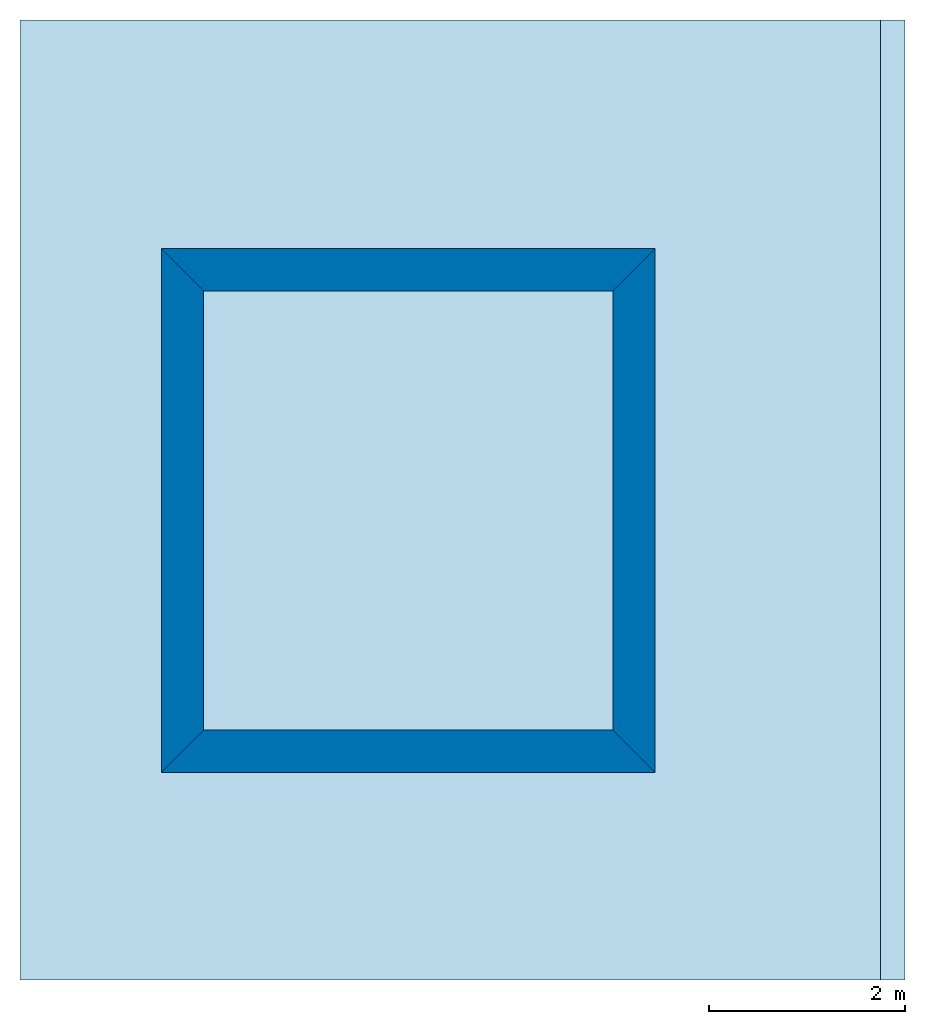
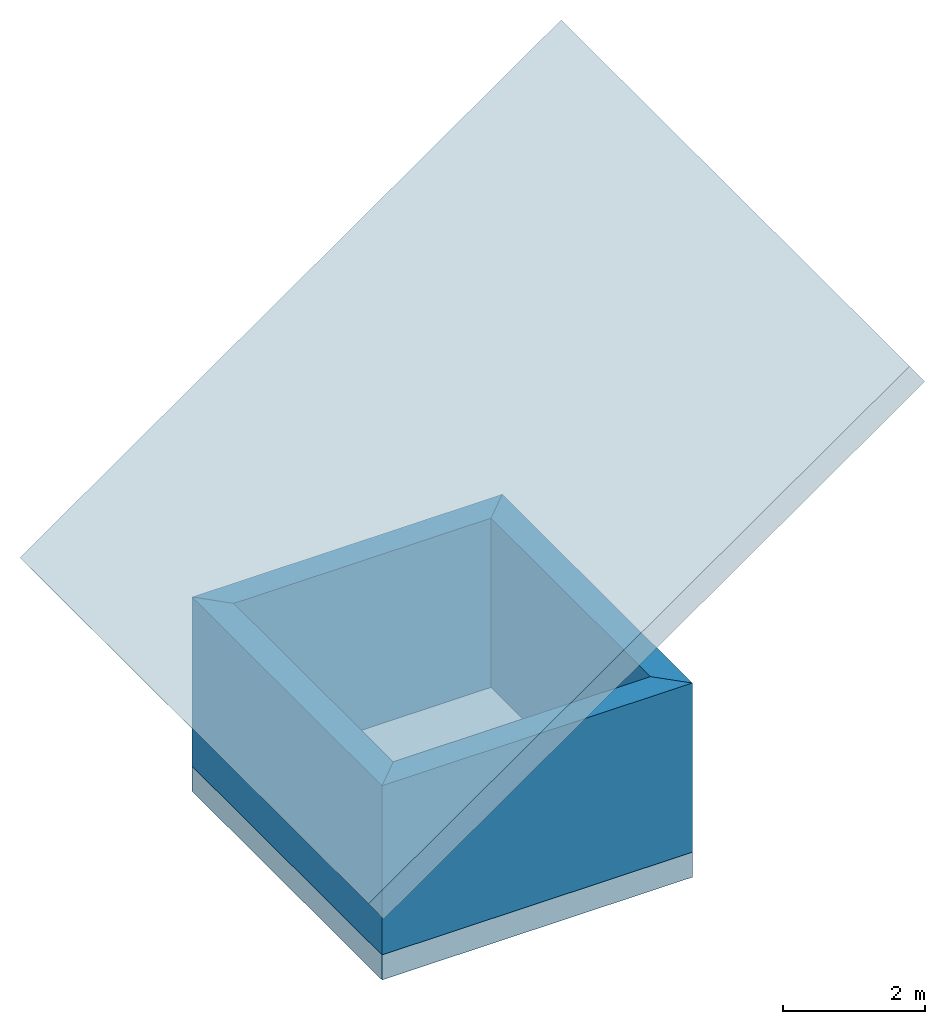
# One storey: 4 walls, 1 roof, 1 slab.
"""IFC4 building model written with IfcOpenShell, lengths in metres."""

from ifc_helpers import new_model, entity, si_unit, converted_unit, derived_unit, direction, frame, origin_with_axes, place, context, subcontext, project, spatial, line, indexed_curve, outline, extrude, material, layer, layer_set, layer_usage, type_object, element, save


model = new_model("IFC4")

# Units and contexts
model_context = context("Model", 3, precision=1e-05, world=origin_with_axes(), true_north=direction((0.0, 1.0)))
body_context = subcontext(model_context, "Body", "Model", "MODEL_VIEW")
ifc_project = project(units=[si_unit("LENGTHUNIT", "METRE"), si_unit("AREAUNIT", "SQUARE_METRE"), si_unit("VOLUMEUNIT", "CUBIC_METRE"), converted_unit("PLANEANGLEUNIT", "DEGREE", entity("IfcPlaneAngleMeasure", 0.0174532925199), si_unit("PLANEANGLEUNIT", "RADIAN"), dimensions=[0, 0, 0, 0, 0, 0, 0]), si_unit("SOLIDANGLEUNIT", "STERADIAN"), converted_unit("TIMEUNIT", "Year", entity("IfcTimeMeasure", 31556926.0), si_unit("TIMEUNIT", "SECOND"), dimensions=[0, 0, 1, 0, 0, 0, 0]), si_unit("MASSUNIT", "GRAM", prefix="KILO"), si_unit("THERMODYNAMICTEMPERATUREUNIT", "DEGREE_CELSIUS"), si_unit("LUMINOUSINTENSITYUNIT", "LUMEN"), si_unit("ENERGYUNIT", "JOULE", prefix="MEGA"), derived_unit("THERMALCONDUCTANCEUNIT", [(si_unit("POWERUNIT", "WATT"), 1), (si_unit("LENGTHUNIT", "METRE"), -1), (si_unit("THERMODYNAMICTEMPERATUREUNIT", "KELVIN"), -1)]), derived_unit("SPECIFICHEATCAPACITYUNIT", [(si_unit("ENERGYUNIT", "JOULE"), 1), (si_unit("MASSUNIT", "GRAM", prefix="KILO"), -1), (si_unit("THERMODYNAMICTEMPERATUREUNIT", "KELVIN"), -1)]), derived_unit("MASSDENSITYUNIT", [(si_unit("MASSUNIT", "GRAM", prefix="KILO"), 1), (si_unit("VOLUMEUNIT", "CUBIC_METRE"), -1)])], contexts=[model_context])

# Site, building, storey
site_placement = place(None, origin_with_axes())
site = spatial("IfcSite", under=ifc_project, at=site_placement, CompositionType="ELEMENT")
building_placement = place(site_placement, origin_with_axes())
building = spatial("IfcBuilding", under=site, at=building_placement, CompositionType="ELEMENT")
storey_placement = place(building_placement, origin_with_axes())
storey = spatial("IfcBuildingStorey", under=building, at=storey_placement, Name="0. Geschoss", CompositionType="ELEMENT", Elevation=0.0)

# Slab
ifc_material = material(Name="ALLGEMEIN")
ifc_layer = layer(ifc_material, 0.43, ventilated="UNKNOWN", Name="Component 1")
ifc_layer_set = layer_set([ifc_layer], Name="ALLGEMEIN - 0.43")
ifc_layer_usage_1 = layer_usage(ifc_layer_set, "AXIS3", "NEGATIVE", 0.43)
slab_type = type_object("IfcSlabType", Name="ALLGEMEIN - 430", PredefinedType="NOTDEFINED")
slab_placement = place(storey_placement, frame((2.63786500696, 0.306960686817, 0.0), z_axis=(0.0, 0.0, 1.0), x_axis=(1.0, 0.0, 0.0)))
element("IfcSlab", 1, at=slab_placement, inside=storey, type_object=slab_type, material=ifc_layer_usage_1, Name="Decke-001", PredefinedType="NOTDEFINED", context=body_context, shape_type="SweptSolid", body=[
    extrude(outline(indexed_curve([(0.0, 0.0), (5.03226133354, 0.0), (5.03226133354, 5.33910653681), (0.0, 5.33910653681)], segments=[line(1, 2, 3, 4, 1)])), frame((0.0, 0.0, -0.43), z_axis=(0.0, 0.0, 1.0), x_axis=(1.0, 0.0, 0.0)), (0.0, 0.0, 1.0), 0.43),
])

# Walls
ifc_layer_usage_2 = layer_usage(ifc_layer_set, "AXIS2", "POSITIVE", 0.0)
wall_type = type_object("IfcWallType", Name="ALLGEMEIN - 430", PredefinedType="NOTDEFINED")
wall_1_placement = place(storey_placement, frame((2.63786500696, 0.306960686817, 0.0), z_axis=(0.0, 0.0, 1.0), x_axis=(1.0, 0.0, 0.0)))
element("IfcWall", 2, at=wall_1_placement, inside=storey, type_object=wall_type, material=ifc_layer_usage_2, Name="Wand-001", PredefinedType="NOTDEFINED", context=body_context, shape_type="SweptSolid", body=[
    extrude(outline(indexed_curve([(0.0, 0.0), (5.03226133354, 0.0), (4.60226133354, 0.43), (0.43, 0.43)], segments=[line(1, 2, 3, 4, 1)])), origin_with_axes(), (0.0, 0.0, 1.0), 2.9),
])
ifc_layer_usage_3 = layer_usage(ifc_layer_set, "AXIS2", "POSITIVE", 0.0)
wall_2_placement = place(storey_placement, frame((7.6701263405, 0.306960686817, 0.0), z_axis=(0.0, 0.0, 1.0), x_axis=(0.0, 1.0, 0.0)))
element("IfcWall", 3, at=wall_2_placement, inside=storey, type_object=wall_type, material=ifc_layer_usage_3, Name="Wand-002", PredefinedType="NOTDEFINED", context=body_context, shape_type="SweptSolid", body=[
    extrude(outline(indexed_curve([(0.0, 0.0), (5.33910653681, 0.0), (4.90910653681, 0.43), (0.43, 0.43)], segments=[line(1, 2, 3, 4, 1)])), origin_with_axes(), (0.0, 0.0, 1.0), 2.9),
])
ifc_layer_usage_4 = layer_usage(ifc_layer_set, "AXIS2", "POSITIVE", 0.0)
wall_3_placement = place(storey_placement, frame((7.6701263405, 5.64606722363, 0.0), z_axis=(0.0, 0.0, 1.0), x_axis=(-1.0, 0.0, 0.0)))
element("IfcWall", 4, at=wall_3_placement, inside=storey, type_object=wall_type, material=ifc_layer_usage_4, Name="Wand-003", PredefinedType="NOTDEFINED", context=body_context, shape_type="SweptSolid", body=[
    extrude(outline(indexed_curve([(0.0, 0.0), (5.03226133354, 0.0), (4.60226133354, 0.43), (0.43, 0.43)], segments=[line(1, 2, 3, 4, 1)])), origin_with_axes(), (0.0, 0.0, 1.0), 2.9),
])
ifc_layer_usage_5 = layer_usage(ifc_layer_set, "AXIS2", "POSITIVE", 0.0)
wall_4_placement = place(storey_placement, frame((2.63786500696, 5.64606722363, 0.0), z_axis=(0.0, 0.0, 1.0), x_axis=(0.0, -1.0, 0.0)))
element("IfcWall", 5, at=wall_4_placement, inside=storey, type_object=wall_type, material=ifc_layer_usage_5, Name="Wand-004", PredefinedType="NOTDEFINED", context=body_context, shape_type="SweptSolid", body=[
    extrude(outline(indexed_curve([(0.0, 0.0), (5.33910653681, 0.0), (4.90910653681, 0.43), (0.43, 0.43)], segments=[line(1, 2, 3, 4, 1)])), origin_with_axes(), (0.0, 0.0, 1.0), 2.9),
])

# Roof
roof_type = type_object("IfcRoofType", Name="ALLGEMEIN - 430", PredefinedType="NOTDEFINED")
roof_placement = place(storey_placement, frame((1.9934900801, 6.41318023179, 2.7), z_axis=(0.0, 0.0, 1.0), x_axis=(0.0, -1.0, 0.0)))
element("IfcRoof", 6, at=roof_placement, inside=storey, type_object=roof_type, material=ifc_material, Name="Dach-001", PredefinedType="NOTDEFINED", context=body_context, shape_type="SweptSolid", body=[
    extrude(outline(indexed_curve([(-1.56491053665, -0.672841708325), (8.2234514475, -0.672841708325), (8.2234514475, 10.040398739), (-1.56491053665, 10.040398739)], segments=[line(1, 2, 3, 4, 1)])), frame((0.0, 0.0, 0.0), z_axis=(0.0, -0.573576436351, 0.819152044289), x_axis=(1.0, 0.0, 0.0)), (0.0, 0.0, 1.0), 0.43),
])

save(model, "model.ifc")
